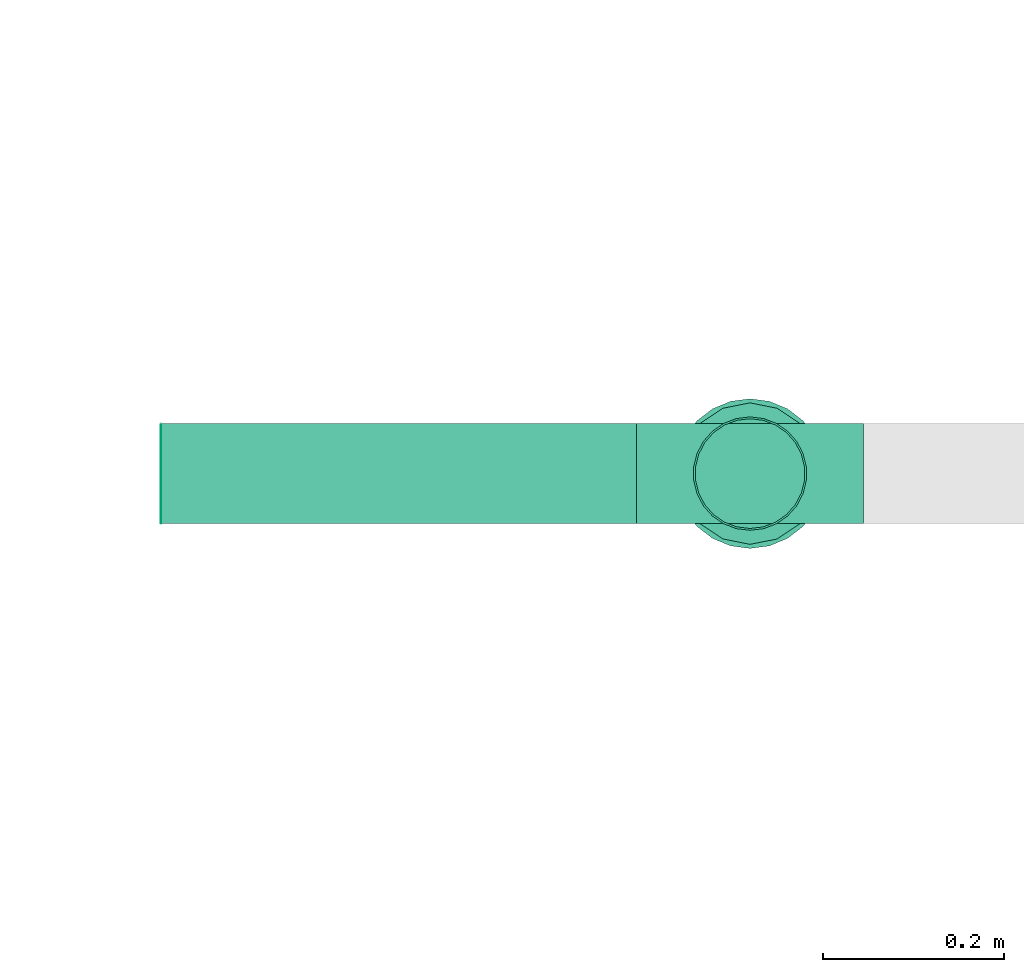
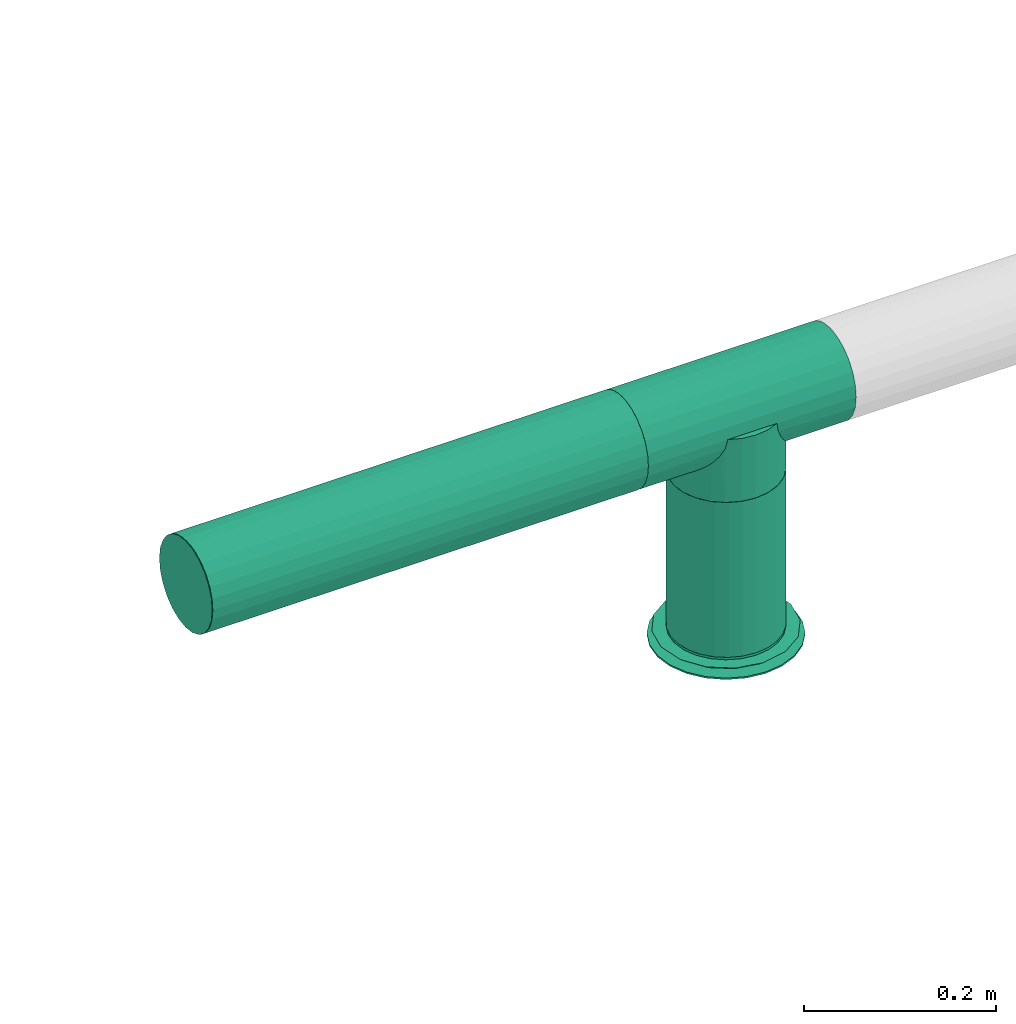
# One storey, part 29 of 115: 2 flow fittings, 2 flow segments, 1 flow terminal.
"""IFC2X3 building model written with IfcOpenShell, lengths in millimetres."""

from ifc_helpers import new_model, entity, si_unit, converted_unit, derived_unit, direction, frame, origin_with_axes, origin_2d_with_axis, place, context, subcontext, project, spatial, hollow_circle, extrude, open_shell, surface_model, source, transform, mapped, material, layer, layer_set, layer_usage, type_object, element, save


model = new_model("IFC2X3")

# Units and contexts
model_context = context("Model", 3, precision=1e-05, world=origin_with_axes(), true_north=direction((0.0, 1.0)))
body_context = subcontext(model_context, "Body", "Model", "MODEL_VIEW")
ifc_project = project(units=[si_unit("AREAUNIT", "SQUARE_METRE"), si_unit("VOLUMEUNIT", "CUBIC_METRE", prefix="DECI"), si_unit("TIMEUNIT", "SECOND"), si_unit("THERMODYNAMICTEMPERATUREUNIT", "DEGREE_CELSIUS"), si_unit("PRESSUREUNIT", "PASCAL"), si_unit("MASSUNIT", "GRAM", prefix="KILO"), si_unit("LENGTHUNIT", "METRE", prefix="MILLI"), si_unit("POWERUNIT", "WATT"), si_unit("ELECTRICCURRENTUNIT", "AMPERE"), si_unit("ELECTRICVOLTAGEUNIT", "VOLT"), derived_unit("VOLUMETRICFLOWRATEUNIT", [(si_unit("VOLUMEUNIT", "CUBIC_METRE", prefix="DECI"), 1), (si_unit("TIMEUNIT", "SECOND"), -1)]), derived_unit("LINEARVELOCITYUNIT", [(si_unit("LENGTHUNIT", "METRE"), 1), (si_unit("TIMEUNIT", "SECOND"), -1)]), derived_unit("MASSDENSITYUNIT", [(si_unit("MASSUNIT", "GRAM", prefix="KILO"), 1), (si_unit("VOLUMEUNIT", "CUBIC_METRE"), -1)]), converted_unit("PLANEANGLEUNIT", "DEGREE", entity("IfcRatioMeasure", 0.01745), si_unit("PLANEANGLEUNIT", "RADIAN"), dimensions=[0, 0, 0, 0, 0, 0, 0])], contexts=[model_context])

# Site, building, storey
site_placement = place(None, origin_with_axes())
site = spatial("IfcSite", under=ifc_project, at=site_placement, CompositionType="ELEMENT")
building_placement = place(site_placement, origin_with_axes())
building = spatial("IfcBuilding", under=site, at=building_placement, Name="mc-building", CompositionType="ELEMENT")
storey_placement = place(building_placement, frame((0.0, 0.0, 2950.0), z_axis=(0.0, 0.0, 1.0), x_axis=(1.0, 0.0, 0.0)))
storey = spatial("IfcBuildingStorey", under=building, at=storey_placement, Name="2. Korrus", CompositionType="ELEMENT", Elevation=2950.0)

# Flow terminal
air_terminal_type = type_object("IfcAirTerminalType", Name="125", PredefinedType="NOTDEFINED")
shared_shape_1 = source(origin_with_axes(), body_context, "Body", "SurfaceModel", [
    surface_model("IfcShellBasedSurfaceModel", [(11.2, 41.25, -71.4471), (11.2, 0.0, -82.5), (11.2, 21.35257, -79.68888), (11.2, 71.4471, -41.25), (11.2, 58.33631, -58.33631), (11.2, 79.68888, -21.35257), (11.2, 82.5, 0.0), (11.2, -79.68888, -21.35257), (11.2, -41.25, -71.4471), (11.2, -21.35257, -79.68888), (11.2, -58.33631, -58.33631), (11.2, -71.4471, -41.25), (11.2, 79.68888, 21.35257), (11.2, 71.4471, 41.25), (11.2, 58.33631, 58.33631), (11.2, 41.25, 71.4471), (11.2, 21.35257, 79.68888), (11.2, -58.33631, 58.33631), (11.2, -21.35257, 79.68888), (11.2, 0.0, 82.5), (11.2, -79.68888, 21.35257), (11.2, -71.4471, 41.25), (11.2, -82.5, 0.0), (11.2, -41.25, 71.4471), (9.2, 21.35257, 79.68888), (9.2, -21.35257, 79.68888), (9.2, 0.0, 82.5), (9.2, 58.33631, 58.33631), (9.2, 41.25, 71.4471), (9.2, 71.4471, 41.25), (9.2, 79.68888, 21.35257), (9.2, -58.33631, 58.33631), (9.2, -41.25, 71.4471), (9.2, -79.68888, 21.35257), (9.2, -71.4471, 41.25), (9.2, -58.33631, -58.33631), (9.2, -82.5, 0.0), (9.2, 79.68888, -21.35257), (9.2, 41.25, -71.4471), (9.2, 71.4471, -41.25), (9.2, -41.25, -71.4471), (9.2, 58.33631, -58.33631), (9.2, 0.0, -82.5), (9.2, 21.35257, -79.68888), (9.2, -71.4471, -41.25), (9.2, -79.68888, -21.35257), (9.2, -21.35257, -79.68888), (9.2, 82.5, 0.0), (9.2, 19.5, 33.77499), (9.2, 0.0, 39.0), (9.2, -19.5, 33.77499), (9.2, -39.0, 0.0), (9.2, 33.77499, 19.5), (9.2, 39.0, 0.0), (9.2, -33.77499, 19.5), (9.2, 0.0, -39.0), (9.2, -33.77499, -19.5), (9.2, -19.5, -33.77499), (9.2, 33.77499, -19.5), (9.2, 19.5, -33.77499), (6.2, 25.24133, 18.3389), (6.2, 31.2, 0.0), (6.2, 9.64133, 29.67296), (6.2, -25.24133, 18.3389), (6.2, -9.64133, 29.67296), (6.2, -31.2, 0.0), (6.2, 25.24133, -18.3389), (6.2, 9.64133, -29.67296), (6.2, -9.64133, -29.67296), (6.2, -25.24133, -18.3389), (9.2, 37.1621, -6.85914), (6.2, 28.22067, -9.16945), (9.2, 35.3242, -13.71829), (6.2, -17.44133, -24.00593), (9.2, -26.6375, -26.6375), (6.2, -28.22067, -9.16945), (9.2, -37.1621, -6.85914), (6.2, 17.44133, -24.00593), (9.2, 9.75, -36.3875), (6.2, 0.0, -29.67296), (9.2, -35.3242, -13.71829), (9.2, 26.6375, -26.6375), (9.2, -9.75, -36.3875), (9.2, -37.1621, 6.85914), (6.2, -28.22067, 9.16945), (9.2, -35.3242, 13.71829), (6.2, 17.44133, 24.00593), (9.2, 26.6375, 26.6375), (6.2, 28.22067, 9.16945), (9.2, 37.1621, 6.85914), (6.2, -17.44133, 24.00593), (9.2, -9.75, 36.3875), (6.2, 0.0, 29.67296), (9.2, 35.3242, 13.71829), (9.2, -26.6375, 26.6375), (9.2, 9.75, 36.3875), (6.2, -26.86438, 64.85634), (6.2, -49.63889, 49.63889), (6.2, -64.85634, 26.86438), (6.2, -70.2, 0.0), (6.2, 64.85634, 26.86438), (6.2, 0.0, 70.2), (6.2, 26.86438, 64.85634), (6.2, 49.63889, 49.63889), (6.2, 70.2, 0.0), (6.2, -64.85634, -26.86438), (6.2, -49.63889, -49.63889), (6.2, -26.86438, -64.85634), (6.2, 26.86438, -64.85634), (6.2, 0.0, -70.2), (6.2, 64.85634, -26.86438), (6.2, 49.63889, -49.63889), (0.0, -29.84931, 72.0626), (0.0, 0.0, 78.0), (0.0, 29.84931, 72.0626), (0.0, 55.15433, 55.15433), (0.0, 78.0, 0.0), (0.0, -55.15433, 55.15433), (0.0, -72.0626, 29.84931), (0.0, -78.0, 0.0), (0.0, 72.0626, 29.84931), (0.0, -72.0626, -29.84931), (0.0, 72.0626, -29.84931), (0.0, 55.15433, -55.15433), (0.0, 29.84931, -72.0626), (0.0, -55.15433, -55.15433), (0.0, -29.84931, -72.0626), (0.0, 0.0, -78.0), (6.2, 66.75025, -17.34304), (0.0, 63.60847, -42.50182), (6.2, 57.24762, -38.25164), (0.0, -14.92465, -75.0313), (6.2, -13.43219, -67.52817), (0.0, 42.50182, -63.60847), (6.2, 38.25164, -57.24762), (0.0, 75.0313, -14.92465), (0.0, 14.92465, -75.0313), (6.2, 13.43219, -67.52817), (0.0, -74.16695, -19.27005), (6.2, -67.52817, -13.43219), (0.0, -42.50182, -63.60847), (6.2, -38.25164, -57.24762), (0.0, -63.60847, -42.50182), (6.2, -57.24762, -38.25164), (6.2, -66.75025, 17.34304), (0.0, -63.60847, 42.50182), (6.2, -57.24762, 38.25164), (0.0, 14.92465, 75.0313), (6.2, 13.43219, 67.52817), (0.0, -42.50182, 63.60847), (6.2, -38.25164, 57.24762), (0.0, -75.0313, 14.92465), (0.0, -14.92465, 75.0313), (6.2, -13.43219, 67.52817), (0.0, 74.16695, 19.27005), (6.2, 67.52817, 13.43219), (0.0, 42.50182, 63.60847), (6.2, 38.25164, 57.24762), (0.0, 63.60847, 42.50182), (6.2, 57.24762, 38.25164), (-3.1, 16.17619, 60.37037), (-3.1, -31.25, 54.12659), (-3.1, 0.0, 62.5), (-3.1, 54.12659, 31.25), (-3.1, 31.25, 54.12659), (-3.1, 44.19417, 44.19417), (-3.1, -54.12659, -31.25), (-3.1, -54.12659, 31.25), (-3.1, -44.19417, 44.19417), (-3.1, -16.17619, 60.37037), (-3.1, -62.5, 0.0), (-3.1, -60.37037, 16.17619), (-3.1, 60.37037, 16.17619), (-3.1, 62.5, 0.0), (-3.1, 60.37037, -16.17619), (-3.1, 54.12659, -31.25), (-3.1, 44.19417, -44.19417), (-3.1, 31.25, -54.12659), (-3.1, 16.17619, -60.37037), (-3.1, -31.25, -54.12659), (-3.1, -44.19417, -44.19417), (-3.1, -60.37037, -16.17619), (-3.1, 0.0, -62.5), (-3.1, -16.17619, -60.37037), (0.0, 31.25, -54.12659), (0.0, -54.12659, -31.25), (0.0, 16.17619, -60.37037), (0.0, 54.12659, -31.25), (0.0, 44.19417, -44.19417), (0.0, 60.37037, -16.17619), (0.0, 62.5, 0.0), (0.0, 54.12659, 31.25), (0.0, 16.17619, 60.37037), (0.0, 0.0, -62.5), (0.0, -31.25, -54.12659), (0.0, -16.17619, -60.37037), (0.0, -44.19417, -44.19417), (0.0, -62.5, 0.0), (0.0, -60.37037, -16.17619), (0.0, 44.19417, 44.19417), (0.0, -54.12659, 31.25), (0.0, 31.25, 54.12659), (0.0, 0.0, 62.5), (0.0, -60.37037, 16.17619), (0.0, -31.25, 54.12659), (0.0, -44.19417, 44.19417), (0.0, -16.17619, 60.37037), (0.0, 60.37037, 16.17619), (-43.1, -14.75269, 55.05777), (-43.1, 0.0, 57.0), (-43.1, 14.75269, 55.05777), (-43.1, 28.5, 49.36345), (-43.1, 40.30508, 40.30508), (-43.1, 49.36345, 28.5), (-43.1, 55.05777, 14.75269), (-43.1, -28.5, 49.36345), (-43.1, -49.36345, 28.5), (-43.1, -40.30508, 40.30508), (-43.1, -57.0, 0.0), (-43.1, -55.05777, 14.75269), (-43.1, -40.30508, -40.30508), (-43.1, 57.0, 0.0), (-43.1, 55.05777, -14.75269), (-43.1, 28.5, -49.36345), (-43.1, 49.36345, -28.5), (-43.1, 14.75269, -55.05777), (-43.1, 40.30508, -40.30508), (-43.1, -49.36345, -28.5), (-43.1, -55.05777, -14.75269), (-43.1, -28.5, -49.36345), (-43.1, 0.0, -57.0), (-43.1, -14.75269, -55.05777), (-3.1, 57.0, 0.0), (-3.1, 14.75269, -55.05777), (-3.1, 28.5, -49.36345), (-3.1, 55.05777, -14.75269), (-3.1, 40.30508, -40.30508), (-3.1, 49.36345, -28.5), (-3.1, 55.05777, 14.75269), (-3.1, -28.5, -49.36345), (-3.1, 0.0, -57.0), (-3.1, -14.75269, -55.05777), (-3.1, -49.36345, -28.5), (-3.1, -57.0, 0.0), (-3.1, -55.05777, -14.75269), (-3.1, -40.30508, -40.30508), (-3.1, -49.36345, 28.5), (-3.1, 49.36345, 28.5), (-3.1, 40.30508, 40.30508), (-3.1, 0.0, 57.0), (-3.1, 28.5, 49.36345), (-3.1, 14.75269, 55.05777), (-3.1, -14.75269, 55.05777), (-3.1, -55.05777, 14.75269), (-3.1, -28.5, 49.36345), (-3.1, -40.30508, 40.30508)], [open_shell([[[0, 1, 2]], [[3, 0, 4]], [[5, 6, 0]], [[5, 0, 3]], [[7, 0, 6]], [[1, 8, 9]], [[1, 0, 8]], [[10, 7, 11]], [[10, 8, 0]], [[7, 10, 0]], [[6, 12, 7]], [[12, 13, 14]], [[12, 14, 15]], [[12, 16, 17]], [[16, 12, 15]], [[18, 16, 19]], [[20, 17, 21]], [[22, 7, 20]], [[17, 18, 23]], [[20, 12, 17]], [[16, 18, 17]], [[20, 7, 12]], [[24, 25, 26]], [[27, 24, 28]], [[27, 29, 30]], [[27, 30, 24]], [[31, 24, 30]], [[25, 31, 32]], [[25, 24, 31]], [[31, 33, 34]], [[31, 30, 33]], [[35, 36, 33]], [[33, 30, 37]], [[33, 37, 35]], [[38, 37, 39]], [[40, 37, 38]], [[38, 39, 41]], [[42, 38, 43]], [[36, 44, 45]], [[35, 44, 36]], [[40, 42, 46]], [[35, 37, 40]], [[38, 42, 40]], [[37, 30, 47]], [[45, 7, 36]], [[44, 11, 45]], [[8, 35, 40]], [[44, 35, 10]], [[9, 40, 46]], [[45, 11, 7]], [[7, 22, 36]], [[9, 8, 40]], [[10, 35, 8]], [[10, 11, 44]], [[1, 9, 46]], [[46, 42, 1]], [[43, 2, 42]], [[38, 0, 43]], [[3, 41, 39]], [[38, 41, 4]], [[5, 39, 37]], [[38, 4, 0]], [[0, 2, 43]], [[6, 5, 37]], [[3, 39, 5]], [[3, 4, 41]], [[47, 6, 37]], [[42, 2, 1]], [[30, 12, 47]], [[29, 13, 30]], [[15, 27, 28]], [[29, 27, 14]], [[16, 28, 24]], [[30, 13, 12]], [[12, 6, 47]], [[16, 15, 28]], [[14, 27, 15]], [[14, 13, 29]], [[19, 16, 24]], [[24, 26, 19]], [[25, 18, 26]], [[32, 23, 25]], [[21, 31, 34]], [[32, 31, 17]], [[20, 34, 33]], [[32, 17, 23]], [[23, 18, 25]], [[36, 22, 20]], [[21, 34, 20]], [[21, 17, 31]], [[33, 36, 20]], [[26, 18, 19]], [[48, 49, 50]], [[50, 51, 52]], [[50, 52, 48]], [[53, 52, 51]], [[50, 54, 51]], [[55, 51, 56]], [[55, 56, 57]], [[58, 55, 59]], [[58, 53, 55]], [[55, 53, 51]], [[60, 61, 62]], [[62, 63, 64]], [[65, 63, 62]], [[62, 61, 65]], [[66, 67, 68]], [[65, 68, 69]], [[65, 61, 68]], [[68, 61, 66]], [[61, 70, 71]], [[58, 71, 72]], [[73, 74, 69]], [[56, 75, 69]], [[76, 51, 65]], [[59, 67, 77]], [[73, 68, 57]], [[74, 73, 57]], [[67, 78, 79]], [[70, 61, 53]], [[65, 75, 76]], [[56, 80, 75]], [[66, 81, 77]], [[82, 57, 68]], [[67, 59, 78]], [[59, 77, 81]], [[81, 66, 58]], [[71, 58, 66]], [[82, 79, 55]], [[78, 55, 79]], [[68, 79, 82]], [[75, 80, 76]], [[56, 69, 74]], [[70, 72, 71]], [[65, 83, 84]], [[54, 84, 85]], [[86, 87, 60]], [[52, 88, 60]], [[89, 53, 61]], [[50, 64, 90]], [[86, 62, 48]], [[87, 86, 48]], [[64, 91, 92]], [[83, 65, 51]], [[61, 88, 89]], [[52, 93, 88]], [[63, 94, 90]], [[95, 48, 62]], [[64, 50, 91]], [[50, 90, 94]], [[94, 63, 54]], [[84, 54, 63]], [[95, 92, 49]], [[91, 49, 92]], [[62, 92, 95]], [[88, 93, 89]], [[52, 60, 87]], [[83, 85, 84]], [[96, 97, 98]], [[98, 99, 96]], [[96, 99, 100]], [[101, 96, 102]], [[100, 103, 102]], [[96, 100, 102]], [[99, 104, 100]], [[105, 106, 107]], [[105, 107, 108]], [[108, 107, 109]], [[110, 104, 111]], [[108, 111, 104]], [[99, 108, 104]], [[108, 99, 105]], [[112, 113, 114]], [[112, 114, 115]], [[116, 112, 115]], [[117, 112, 118]], [[119, 118, 112]], [[119, 112, 116]], [[116, 115, 120]], [[121, 116, 122]], [[123, 124, 122]], [[121, 122, 124]], [[125, 121, 126]], [[126, 121, 124]], [[124, 127, 126]], [[116, 121, 119]], [[110, 122, 128]], [[111, 129, 130]], [[107, 131, 132]], [[108, 133, 134]], [[104, 128, 135]], [[116, 104, 135]], [[111, 134, 123]], [[130, 122, 110]], [[136, 124, 137]], [[128, 122, 135]], [[127, 136, 109]], [[111, 123, 129]], [[119, 138, 139]], [[138, 105, 139]], [[140, 141, 106]], [[124, 108, 137]], [[139, 99, 119]], [[108, 124, 133]], [[106, 125, 140]], [[142, 143, 105]], [[123, 134, 133]], [[131, 127, 132]], [[106, 143, 125]], [[141, 126, 107]], [[126, 141, 140]], [[109, 136, 137]], [[138, 121, 105]], [[122, 130, 129]], [[125, 143, 142]], [[107, 126, 131]], [[127, 109, 132]], [[105, 121, 142]], [[98, 118, 144]], [[97, 145, 146]], [[102, 147, 148]], [[96, 149, 150]], [[99, 144, 151]], [[119, 99, 151]], [[97, 150, 117]], [[146, 118, 98]], [[152, 112, 153]], [[144, 118, 151]], [[113, 152, 101]], [[97, 117, 145]], [[116, 154, 155]], [[154, 100, 155]], [[156, 157, 103]], [[112, 96, 153]], [[155, 104, 116]], [[96, 112, 149]], [[103, 115, 156]], [[158, 159, 100]], [[117, 150, 149]], [[147, 113, 148]], [[103, 159, 115]], [[157, 114, 102]], [[114, 157, 156]], [[101, 152, 153]], [[154, 120, 100]], [[118, 146, 145]], [[115, 159, 158]], [[102, 114, 147]], [[113, 101, 148]], [[100, 120, 158]], [[160, 161, 162]], [[163, 160, 164]], [[161, 160, 163]], [[163, 164, 165]], [[163, 166, 167]], [[161, 167, 168]], [[161, 169, 162]], [[167, 170, 171]], [[167, 161, 163]], [[166, 170, 167]], [[163, 172, 173]], [[173, 174, 175]], [[173, 175, 176]], [[177, 178, 173]], [[177, 173, 176]], [[173, 178, 179]], [[166, 179, 180]], [[181, 170, 166]], [[179, 182, 183]], [[166, 163, 179]], [[182, 179, 178]], [[163, 173, 179]], [[184, 185, 186]], [[187, 184, 188]], [[187, 189, 190]], [[184, 187, 191]], [[192, 185, 184]], [[193, 194, 195]], [[193, 186, 194]], [[194, 185, 196]], [[186, 185, 194]], [[185, 197, 198]], [[190, 191, 187]], [[191, 192, 184]], [[192, 191, 199]], [[192, 200, 185]], [[192, 199, 201]], [[202, 200, 192]], [[197, 200, 203]], [[185, 200, 197]], [[200, 204, 205]], [[202, 204, 200]], [[202, 206, 204]], [[191, 190, 207]], [[172, 207, 173]], [[163, 191, 172]], [[201, 165, 164]], [[163, 165, 199]], [[192, 164, 160]], [[172, 191, 207]], [[207, 190, 173]], [[192, 201, 164]], [[199, 165, 201]], [[199, 191, 163]], [[202, 192, 160]], [[160, 162, 202]], [[169, 206, 162]], [[161, 204, 169]], [[200, 168, 167]], [[161, 168, 205]], [[203, 167, 171]], [[161, 205, 204]], [[204, 206, 169]], [[197, 203, 171]], [[200, 167, 203]], [[200, 205, 168]], [[170, 197, 171]], [[162, 206, 202]], [[181, 198, 170]], [[166, 185, 181]], [[194, 180, 179]], [[166, 180, 196]], [[195, 179, 183]], [[181, 185, 198]], [[198, 197, 170]], [[195, 194, 179]], [[196, 180, 194]], [[196, 185, 166]], [[193, 195, 183]], [[183, 182, 193]], [[178, 186, 182]], [[177, 184, 178]], [[187, 176, 175]], [[177, 176, 188]], [[189, 175, 174]], [[177, 188, 184]], [[184, 186, 178]], [[190, 189, 174]], [[187, 175, 189]], [[187, 188, 176]], [[173, 190, 174]], [[182, 186, 193]], [[208, 209, 210]], [[211, 208, 210]], [[212, 213, 214]], [[212, 214, 211]], [[208, 211, 214]], [[215, 216, 217]], [[216, 215, 208]], [[216, 218, 219]], [[216, 208, 214]], [[216, 220, 218]], [[216, 214, 221]], [[220, 216, 222]], [[223, 222, 224]], [[223, 225, 222]], [[223, 224, 226]], [[220, 222, 225]], [[218, 227, 228]], [[220, 227, 218]], [[229, 230, 231]], [[229, 220, 225]], [[230, 229, 225]], [[216, 221, 222]], [[232, 233, 234]], [[235, 234, 236]], [[235, 232, 234]], [[235, 236, 237]], [[238, 239, 233]], [[240, 239, 241]], [[240, 233, 239]], [[242, 243, 244]], [[245, 239, 246]], [[242, 245, 243]], [[238, 233, 232]], [[238, 247, 248]], [[238, 248, 249]], [[250, 251, 249]], [[250, 249, 248]], [[238, 249, 252]], [[243, 246, 253]], [[245, 246, 243]], [[246, 254, 255]], [[254, 246, 252]], [[238, 252, 246]], [[246, 239, 238]], [[214, 238, 221]], [[213, 247, 214]], [[250, 212, 211]], [[213, 212, 248]], [[251, 211, 210]], [[214, 247, 238]], [[238, 232, 221]], [[251, 250, 211]], [[248, 212, 250]], [[248, 247, 213]], [[249, 251, 210]], [[210, 209, 249]], [[254, 215, 217]], [[246, 216, 219]], [[217, 216, 255]], [[253, 219, 218]], [[208, 254, 252]], [[208, 215, 254]], [[252, 249, 208]], [[217, 255, 254]], [[216, 246, 255]], [[253, 246, 219]], [[218, 243, 253]], [[208, 249, 209]], [[228, 244, 218]], [[227, 242, 228]], [[239, 220, 229]], [[227, 220, 245]], [[241, 229, 231]], [[228, 242, 244]], [[244, 243, 218]], [[241, 239, 229]], [[245, 220, 239]], [[245, 242, 227]], [[240, 241, 231]], [[231, 230, 240]], [[233, 230, 225]], [[234, 225, 223]], [[237, 224, 222]], [[221, 235, 222]], [[225, 234, 233]], [[234, 223, 226]], [[234, 226, 236]], [[226, 224, 236]], [[224, 237, 236]], [[235, 237, 222]], [[221, 232, 235]], [[230, 233, 240]]])]),
])
flow_terminal_placement = place(storey_placement, frame((12118.92187, 6254.72535, 2200.0), z_axis=(1.0, 0.0, 0.0), x_axis=(0.0, 0.0, -1.0)))
element("IfcFlowTerminal", 1, at=flow_terminal_placement, inside=storey, type_object=air_terminal_type, Name="125", context=body_context, shape_type="MappedRepresentation", body=[
    mapped(shared_shape_1, transform((0.0, 0.0, 0.0), scale=1.0)),
])

# Flow segment
ifc_material = material(Name="FZ1")
ifc_layer = layer(ifc_material, 0.0)
ifc_layer_set = layer_set([ifc_layer], Name="FZ1")
ifc_layer_usage = layer_usage(ifc_layer_set, "AXIS1", "POSITIVE", 0.0)
duct_segment_type = type_object("IfcDuctSegmentType", PredefinedType="RIGIDSEGMENT")
shared_shape_2 = source(origin_with_axes(), body_context, "Body", "SweptSolid", [
    extrude(hollow_circle(Radius=55.0, WallThickness=2.0, at=origin_2d_with_axis()), frame((0.0, 0.0, 0.0), z_axis=(1.0, 0.0, 0.0), x_axis=(0.0, 1.0, 0.0)), (0.0, 0.0, 1.0), 523.9),
])
flow_segment_1_placement = place(storey_placement, frame((11993.92187, 6254.72535, 2480.0), z_axis=(0.0, 0.0, 1.0), x_axis=(-1.0, 0.0, 0.0)))
element("IfcFlowSegment", 2, at=flow_segment_1_placement, inside=storey, type_object=duct_segment_type, material=ifc_layer_usage, context=body_context, shape_type="MappedRepresentation", body=[
    mapped(shared_shape_2, transform((0.0, 0.0, 0.0), scale=1.0)),
])

# Flow fittings
duct_fitting_type_1 = type_object("IfcDuctFittingType", PredefinedType="JUNCTION")
shared_shape_3 = source(origin_with_axes(), body_context, "Body", "SurfaceModel", [
    surface_model("IfcShellBasedSurfaceModel", [(0.0, -80.0, -62.5), (16.17619, -80.0, -60.37037), (-16.17619, -80.0, -60.37037), (-60.37037, -80.0, 16.17619), (-31.25, -80.0, -54.12659), (-44.19417, -80.0, -44.19417), (-54.12659, -80.0, -31.25), (62.5, -80.0, 0.0), (60.37037, -80.0, 16.17619), (44.19417, -80.0, -44.19417), (31.25, -80.0, -54.12659), (60.37037, -80.0, -16.17619), (54.12659, -80.0, -31.25), (-60.37037, -80.0, -16.17619), (-54.12659, -80.0, 31.25), (-44.19417, -80.0, 44.19417), (-31.25, -80.0, 54.12659), (-16.17619, -80.0, 60.37037), (16.17619, -80.0, 60.37037), (54.12659, -80.0, 31.25), (44.19417, -80.0, 44.19417), (31.25, -80.0, 54.12659), (0.0, -80.0, 62.5), (-62.5, -80.0, 0.0), (0.0, 0.0, 62.5), (-15.31424, 0.0, 60.59475), (-29.68586, 0.0, 55.0), (-31.79332, -11.38268, 53.80924), (-62.5, -55.0, 0.0), (-61.43518, -80.0, 8.0881), (-61.42389, -53.77401, 11.548), (-36.65815, -21.50744, 50.62045), (-42.49909, -30.41254, 45.8266), (-48.42243, -38.25549, 39.51605), (-53.88367, -44.96887, 31.66703), (-58.39386, -50.28512, 22.28019), (-61.42389, -53.77401, -11.548), (-58.39386, -50.28512, -22.28019), (-53.88367, -44.96887, -31.66703), (-48.42243, -38.25549, -39.51605), (-61.43518, -80.0, -8.0881), (-42.49909, -30.41254, -45.8266), (-31.79332, -11.38268, -53.80924), (-29.68586, 0.0, -55.0), (-15.31424, 0.0, -60.59475), (0.0, 0.0, -62.5), (-36.65815, -21.50744, -50.62045), (15.31424, 0.0, -60.59475), (29.68586, 0.0, -55.0), (31.79332, -11.38268, -53.80924), (62.5, -55.0, 0.0), (61.43518, -80.0, -8.0881), (61.42389, -53.77401, -11.548), (36.65815, -21.50744, -50.62045), (42.49909, -30.41254, -45.8266), (48.42243, -38.25549, -39.51605), (53.88367, -44.96887, -31.66703), (58.39386, -50.28512, -22.28019), (61.42389, -53.77401, 11.548), (58.39386, -50.28512, 22.28019), (53.88367, -44.96887, 31.66703), (48.42243, -38.25549, 39.51605), (61.43518, -80.0, 8.0881), (42.49909, -30.41254, 45.8266), (31.79332, -11.38268, 53.80924), (29.68586, 0.0, 55.0), (15.31424, 0.0, 60.59475), (36.65815, -21.50744, 50.62045), (-125.0, 0.0, -55.0), (-125.0, -14.23505, -53.12592), (-125.0, 14.23505, -53.12592), (-125.0, 53.12592, 14.23505), (-125.0, 27.5, -47.63139), (-125.0, 47.63139, -27.5), (-125.0, 38.89087, -38.89087), (-125.0, -55.0, 0.0), (-125.0, -53.12592, 14.23505), (-125.0, -38.89087, -38.89087), (-125.0, -27.5, -47.63139), (-125.0, -53.12592, -14.23505), (-125.0, -47.63139, -27.5), (-125.0, 53.12592, -14.23505), (-125.0, 47.63139, 27.5), (-125.0, 38.89087, 38.89087), (-125.0, -14.23505, 53.12592), (-125.0, 27.5, 47.63139), (-125.0, 14.23505, 53.12592), (-125.0, -47.63139, 27.5), (-125.0, -38.89087, 38.89087), (-125.0, -27.5, 47.63139), (-125.0, 0.0, 55.0), (-125.0, 55.0, 0.0), (125.0, 55.0, 0.0), (125.0, 0.0, -55.0), (125.0, 14.23505, -53.12592), (125.0, 27.5, -47.63139), (125.0, 38.89087, -38.89087), (125.0, 47.63139, -27.5), (125.0, -38.89087, -38.89087), (125.0, -53.12592, 14.23505), (125.0, -27.5, -47.63139), (125.0, -14.23505, -53.12592), (125.0, -47.63139, -27.5), (125.0, -53.12592, -14.23505), (125.0, -55.0, 0.0), (125.0, 53.12592, -14.23505), (125.0, 53.12592, 14.23505), (125.0, 47.63139, 27.5), (125.0, 38.89087, 38.89087), (125.0, 0.0, 55.0), (125.0, 27.5, 47.63139), (125.0, 14.23505, 53.12592), (125.0, -47.63139, 27.5), (125.0, -38.89087, 38.89087), (125.0, -27.5, 47.63139), (125.0, -14.23505, 53.12592)], [open_shell([[[0, 1, 2]], [[2, 3, 4]], [[5, 3, 6]], [[4, 3, 5]], [[2, 7, 8]], [[9, 7, 10]], [[1, 10, 7]], [[11, 7, 12]], [[9, 12, 7]], [[7, 2, 1]], [[13, 6, 3]], [[2, 14, 3]], [[2, 15, 14]], [[16, 2, 17]], [[16, 15, 2]], [[17, 2, 18]], [[19, 20, 2]], [[19, 2, 8]], [[20, 21, 2]], [[2, 21, 18]], [[18, 22, 17]], [[23, 13, 3]], [[22, 24, 25]], [[26, 27, 25]], [[28, 29, 30]], [[17, 25, 27]], [[22, 25, 17]], [[16, 31, 32]], [[16, 17, 27]], [[16, 32, 15]], [[31, 16, 27]], [[33, 34, 14]], [[35, 30, 3]], [[34, 35, 14]], [[15, 33, 14]], [[30, 29, 3]], [[3, 14, 35]], [[29, 28, 23]], [[33, 15, 32]], [[36, 37, 13]], [[38, 39, 6]], [[37, 38, 6]], [[36, 40, 28]], [[28, 40, 23]], [[13, 37, 6]], [[39, 5, 6]], [[39, 41, 5]], [[42, 43, 44]], [[36, 13, 40]], [[42, 44, 2]], [[0, 44, 45]], [[41, 46, 4]], [[42, 4, 46]], [[42, 2, 4]], [[44, 0, 2]], [[41, 4, 5]], [[0, 45, 47]], [[48, 49, 47]], [[50, 51, 52]], [[1, 47, 49]], [[0, 47, 1]], [[10, 53, 54]], [[10, 1, 49]], [[10, 54, 9]], [[53, 10, 49]], [[55, 56, 12]], [[57, 52, 11]], [[56, 57, 12]], [[9, 55, 12]], [[52, 51, 11]], [[11, 12, 57]], [[51, 50, 7]], [[55, 9, 54]], [[58, 59, 8]], [[60, 61, 19]], [[59, 60, 19]], [[58, 62, 50]], [[7, 50, 62]], [[59, 19, 8]], [[61, 20, 19]], [[61, 63, 20]], [[64, 65, 66]], [[58, 8, 62]], [[64, 66, 18]], [[22, 66, 24]], [[63, 67, 21]], [[64, 21, 67]], [[64, 18, 21]], [[66, 22, 18]], [[63, 21, 20]], [[68, 69, 70]], [[70, 71, 72]], [[73, 74, 71]], [[72, 71, 74]], [[70, 75, 76]], [[77, 75, 78]], [[69, 78, 75]], [[79, 75, 80]], [[77, 80, 75]], [[75, 70, 69]], [[73, 71, 81]], [[70, 82, 71]], [[70, 83, 82]], [[70, 84, 85]], [[85, 83, 70]], [[84, 86, 85]], [[70, 87, 88]], [[87, 70, 76]], [[88, 89, 70]], [[70, 89, 84]], [[84, 90, 86]], [[91, 81, 71]], [[92, 93, 94]], [[95, 92, 94]], [[92, 96, 97]], [[96, 92, 95]], [[98, 93, 99]], [[93, 98, 100]], [[100, 101, 93]], [[98, 99, 102]], [[102, 99, 103]], [[104, 103, 99]], [[105, 92, 97]], [[106, 107, 93]], [[93, 107, 108]], [[109, 93, 110]], [[93, 108, 110]], [[109, 110, 111]], [[112, 99, 93]], [[113, 112, 93]], [[114, 113, 93]], [[115, 114, 93]], [[115, 93, 109]], [[92, 106, 93]], [[65, 109, 111]], [[65, 111, 86]], [[85, 111, 110]], [[90, 26, 86]], [[86, 26, 65]], [[111, 85, 86]], [[110, 83, 85]], [[82, 108, 107]], [[71, 107, 106]], [[91, 106, 92]], [[83, 108, 82]], [[82, 107, 71]], [[106, 91, 71]], [[108, 83, 110]], [[81, 92, 105]], [[73, 105, 97]], [[74, 97, 96]], [[91, 92, 81]], [[81, 105, 73]], [[97, 74, 73]], [[96, 72, 74]], [[70, 95, 94]], [[93, 48, 94]], [[43, 94, 48]], [[72, 95, 70]], [[43, 68, 70]], [[94, 43, 70]], [[95, 72, 96]], [[68, 43, 42]], [[69, 42, 46]], [[78, 46, 41]], [[68, 42, 69]], [[77, 41, 39]], [[78, 69, 46]], [[41, 77, 78]], [[38, 37, 80]], [[36, 28, 75]], [[37, 36, 79]], [[77, 38, 80]], [[80, 37, 79]], [[36, 75, 79]], [[38, 77, 39]], [[49, 93, 101]], [[101, 100, 53]], [[98, 54, 100]], [[98, 55, 54]], [[48, 93, 49]], [[49, 101, 53]], [[100, 54, 53]], [[56, 98, 102]], [[57, 102, 103]], [[52, 103, 104]], [[57, 56, 102]], [[50, 52, 104]], [[57, 103, 52]], [[98, 56, 55]], [[28, 30, 75]], [[35, 34, 87]], [[30, 35, 76]], [[75, 30, 76]], [[76, 35, 87]], [[34, 88, 87]], [[34, 33, 88]], [[89, 32, 31]], [[31, 27, 84]], [[26, 90, 27]], [[32, 88, 33]], [[32, 89, 88]], [[89, 31, 84]], [[27, 90, 84]], [[58, 104, 99]], [[59, 99, 112]], [[60, 112, 113]], [[58, 50, 104]], [[60, 59, 112]], [[58, 99, 59]], [[113, 61, 60]], [[61, 113, 63]], [[63, 113, 114]], [[67, 114, 115]], [[64, 115, 109]], [[63, 114, 67]], [[64, 67, 115]], [[65, 64, 109]], [[65, 26, 24]], [[65, 24, 66]], [[24, 26, 25]], [[47, 45, 48]], [[43, 48, 45]], [[43, 45, 44]]])]),
])
flow_fitting_1_placement = place(storey_placement, frame((12118.92187, 6254.72535, 2480.0), z_axis=(0.0, 1.0, 0.0), x_axis=(-1.0, 0.0, 0.0)))
element("IfcFlowFitting", 3, at=flow_fitting_1_placement, inside=storey, type_object=duct_fitting_type_1, context=body_context, shape_type="MappedRepresentation", body=[
    mapped(shared_shape_3, transform((0.0, 0.0, 0.0), scale=1.0)),
])
duct_fitting_type_2 = type_object("IfcDuctFittingType", Name="EPF", PredefinedType="OBSTRUCTION")
shared_shape_4 = source(origin_with_axes(), body_context, "Body", "SurfaceModel", [
    surface_model("IfcShellBasedSurfaceModel", [(0.0, -55.0, 0.0), (0.0, -53.12592, 14.23505), (0.0, 0.0, -55.0), (0.0, 14.23505, -53.12592), (0.0, 53.12592, 14.23505), (0.0, 27.5, -47.63139), (0.0, 47.63139, -27.5), (0.0, 38.89087, -38.89087), (0.0, -27.5, 47.63139), (0.0, -38.89087, -38.89087), (0.0, -27.5, -47.63139), (0.0, -14.23505, -53.12592), (0.0, -53.12592, -14.23505), (0.0, -47.63139, -27.5), (0.0, 53.12592, -14.23505), (0.0, 47.63139, 27.5), (0.0, 38.89087, 38.89087), (0.0, 14.23505, 53.12592), (0.0, 27.5, 47.63139), (0.0, -14.23505, 53.12592), (0.0, -47.63139, 27.5), (0.0, -38.89087, 38.89087), (0.0, 0.0, 55.0), (0.0, 55.0, 0.0), (0.8, 14.23505, -53.12592), (0.8, 53.12592, 14.23505), (0.8, 0.0, -55.0), (0.8, 27.5, -47.63139), (0.8, 55.0, 0.0), (0.8, 38.89087, -38.89087), (0.8, 47.63139, -27.5), (0.8, -38.89087, -38.89087), (0.8, -53.12592, 14.23505), (0.8, -27.5, -47.63139), (0.8, -14.23505, -53.12592), (0.8, -47.63139, -27.5), (0.8, -53.12592, -14.23505), (0.8, -55.0, 0.0), (0.8, 53.12592, -14.23505), (0.8, 47.63139, 27.5), (0.8, 38.89087, 38.89087), (0.8, 27.5, 47.63139), (0.8, 0.0, 55.0), (0.8, 14.23505, 53.12592), (0.8, -47.63139, 27.5), (0.8, -38.89087, 38.89087), (0.8, -27.5, 47.63139), (0.8, -14.23505, 53.12592)], [open_shell([[[0, 1, 2]], [[3, 4, 5]], [[6, 7, 4]], [[4, 7, 5]], [[2, 8, 3]], [[9, 0, 10]], [[11, 10, 0]], [[12, 0, 13]], [[9, 13, 0]], [[0, 2, 11]], [[4, 14, 6]], [[4, 3, 15]], [[16, 15, 3]], [[3, 17, 18]], [[16, 3, 18]], [[3, 19, 17]], [[2, 1, 20]], [[2, 20, 21]], [[2, 21, 8]], [[19, 3, 8]], [[19, 22, 17]], [[23, 14, 4]], [[24, 25, 26]], [[27, 25, 24]], [[28, 29, 30]], [[27, 29, 25]], [[31, 26, 32]], [[26, 31, 33]], [[33, 34, 26]], [[31, 32, 35]], [[35, 32, 36]], [[37, 36, 32]], [[28, 30, 38]], [[25, 39, 26]], [[26, 39, 40]], [[26, 41, 42]], [[41, 26, 40]], [[41, 43, 42]], [[44, 32, 26]], [[45, 44, 26]], [[46, 45, 26]], [[46, 26, 47]], [[42, 47, 26]], [[28, 25, 29]], [[22, 42, 43]], [[17, 43, 41]], [[22, 43, 17]], [[18, 40, 16]], [[18, 17, 41]], [[40, 18, 41]], [[15, 39, 25]], [[4, 25, 28]], [[16, 39, 15]], [[4, 15, 25]], [[23, 4, 28]], [[39, 16, 40]], [[23, 28, 38]], [[14, 38, 30]], [[23, 38, 14]], [[6, 29, 7]], [[6, 14, 30]], [[29, 6, 30]], [[5, 27, 24]], [[3, 24, 26]], [[7, 27, 5]], [[3, 5, 24]], [[2, 3, 26]], [[27, 7, 29]], [[2, 26, 34]], [[11, 34, 33]], [[2, 34, 11]], [[10, 31, 9]], [[10, 11, 33]], [[31, 10, 33]], [[13, 35, 36]], [[12, 36, 37]], [[9, 35, 13]], [[12, 13, 36]], [[0, 12, 37]], [[35, 9, 31]], [[0, 37, 32]], [[1, 32, 44]], [[0, 32, 1]], [[20, 45, 21]], [[20, 1, 44]], [[45, 20, 44]], [[8, 46, 47]], [[19, 47, 42]], [[21, 46, 8]], [[19, 8, 47]], [[22, 19, 42]], [[46, 21, 45]]])]),
])
flow_fitting_2_placement = place(storey_placement, frame((11469.98441, 6254.72535, 2480.0), z_axis=(0.0, 0.0, 1.0), x_axis=(-1.0, 0.0, 0.0)))
element("IfcFlowFitting", 4, at=flow_fitting_2_placement, inside=storey, type_object=duct_fitting_type_2, context=body_context, shape_type="MappedRepresentation", body=[
    mapped(shared_shape_4, transform((0.0, 0.0, 0.0), scale=1.0)),
])

# Flow segment
shared_shape_5 = source(origin_with_axes(), body_context, "Body", "SweptSolid", [
    extrude(hollow_circle(Radius=62.5, WallThickness=2.0, at=origin_2d_with_axis()), frame((0.0, 0.0, 0.0), z_axis=(1.0, 0.0, 0.0), x_axis=(0.0, 1.0, 0.0)), (0.0, 0.0, 1.0), 196.9),
])
flow_segment_2_placement = place(storey_placement, frame((12118.92187, 6254.72535, 2400.0), z_axis=(1.0, 0.0, 0.0), x_axis=(0.0, 0.0, -1.0)))
element("IfcFlowSegment", 5, at=flow_segment_2_placement, inside=storey, type_object=duct_segment_type, material=ifc_layer_usage, context=body_context, shape_type="MappedRepresentation", body=[
    mapped(shared_shape_5, transform((0.0, 0.0, 0.0), scale=1.0)),
])

save(model, "model.ifc")
